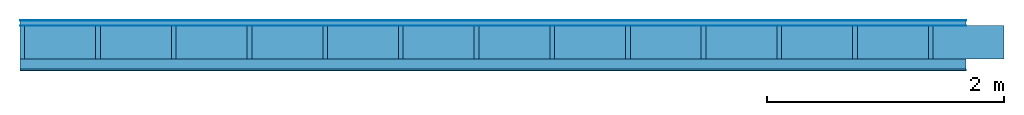
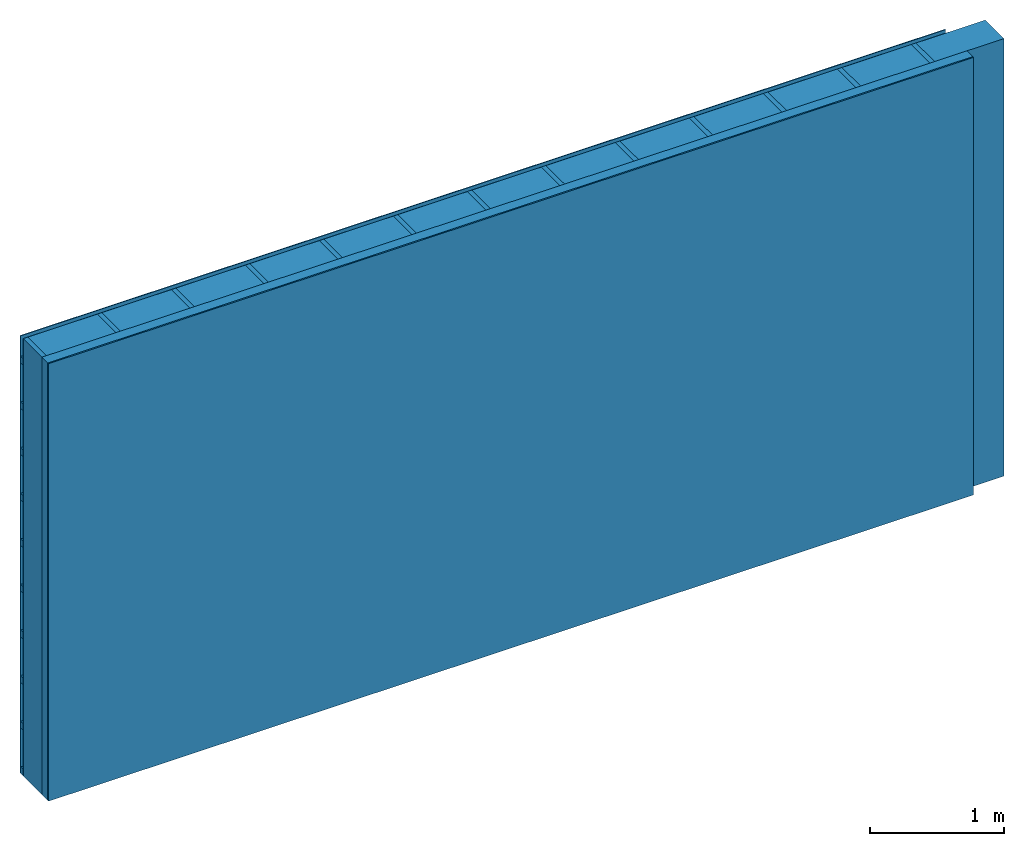
# One storey: 4 plates, 3 members, 1 element without a shape of its own.
"""IFC4 building model written with IfcOpenShell, lengths in metres."""

from ifc_helpers import new_model, si_unit, derived_unit, direction, frame, frame_2d, origin, origin_with_axes, place, context, project, spatial, rectangle, extrude, material, layer, layer_set, type_object, element, aggregate, save


model = new_model("IFC4")

# Units and contexts
plan_context = context("Plan", 3, precision=1e-05, world=origin(), true_north=direction((0.0, 1.0)))
model_context = context("Model", 3, precision=1e-05, world=origin(), true_north=direction((0.0, 1.0)))
ifc_project = project(units=[si_unit("LENGTHUNIT", "METRE"), derived_unit("SOUNDPRESSUREUNIT", [(si_unit("PRESSUREUNIT", "PASCAL", prefix="MICRO"), 0)]), si_unit("ENERGYUNIT", "JOULE", prefix="MEGA"), si_unit("MASSUNIT", "GRAM", prefix="KILO"), derived_unit("THERMALTRANSMITTANCEUNIT", [(si_unit("POWERUNIT", "WATT"), 1), (si_unit("AREAUNIT", "SQUARE_METRE"), -1), (si_unit("THERMODYNAMICTEMPERATUREUNIT", "KELVIN"), -1)]), derived_unit("AREADENSITYUNIT", [(si_unit("MASSUNIT", "GRAM", prefix="KILO"), 1), (si_unit("AREAUNIT", "SQUARE_METRE"), -1)]), derived_unit("USERDEFINED", [(si_unit("ENERGYUNIT", "JOULE", prefix="MEGA"), 1), (si_unit("AREAUNIT", "SQUARE_METRE"), -1)])], contexts=[plan_context, model_context])

# Site, building, storey
site = spatial("IfcSite", under=ifc_project)
building_placement = place(None, origin())
building = spatial("IfcBuilding", under=site, at=building_placement)
storey_placement = place(building_placement, origin())
storey = spatial("IfcBuildingStorey", under=building, at=storey_placement)

# Wall, members, plates
ifc_material_1 = material(Name="mineral, cement-based building board", Category="03.003")
ifc_layer_1 = layer(ifc_material_1, 0.008, Name="Cover 1st layer")
ifc_layer_2 = layer(None, 0.04, Name="Battens / profiles (ventilation)")
ifc_material_2 = material(Name="Vapor-permeable water barrier", Category="09.006")
ifc_layer_3 = layer(ifc_material_2, 0.0005, Name="outside 1st layer")
ifc_material_3 = material(Name="of the art")
ifc_layer_4 = layer(ifc_material_3, 0.0, Name="Bond")
ifc_layer_5 = layer(None, 0.28, Name="Support")
ifc_layer_6 = layer(ifc_material_3, 0.0, Name="Bond")
ifc_material_4 = material(Name="Solid timber panel")
ifc_layer_7 = layer(ifc_material_4, 0.087, Name="1st layer")
ifc_material_5 = material(Name="Plasterboard type A", Category="03.008")
ifc_layer_8 = layer(ifc_material_5, 0.0125, Name="Covering 1st layer")
ifc_material_6 = material(Name="joints", Category="04.017")
ifc_layer_9 = layer(ifc_material_6, 0.0, Name="Surface")
ifc_layer_set = layer_set([ifc_layer_1, ifc_layer_2, ifc_layer_3, ifc_layer_4, ifc_layer_5, ifc_layer_6, ifc_layer_7, ifc_layer_8, ifc_layer_9])
wall_type = type_object("IfcWallType", Name="D0997", PredefinedType="NOTDEFINED", material=ifc_layer_set)
wall_placement = place(None, frame((0.0, 0.0, 0.0), z_axis=(0.0, -1.0, 0.0), x_axis=(1.0, 0.0, 0.0)))
wall = element("IfcWall", 1, at=wall_placement, inside=storey, type_object=wall_type, material=ifc_layer_set, Name="Wall #1")
ifc_material_7 = material()
member_1_placement = place(wall_placement, origin())
member_1 = element("IfcMember", 2, at=member_1_placement, material=ifc_material_7, Name="Battens / profiles (ventilation)", context=plan_context, shape_type="SweptSolid", body=[
    extrude(rectangle(XDim=0.06, YDim=0.04, at=frame_2d((0.03, 0.02), x_axis=(1.0, 0.0))), frame((0.0, 0.0, 0.008), z_axis=(1.0, 0.0, 0.0), x_axis=(0.0, 1.0, 0.0)), (0.0, 0.0, 1.0), 8.0),
    extrude(rectangle(XDim=0.06, YDim=0.04, at=frame_2d((0.03, 0.02), x_axis=(1.0, 0.0))), frame((0.0, 0.417, 0.008), z_axis=(1.0, 0.0, 0.0), x_axis=(0.0, 1.0, 0.0)), (0.0, 0.0, 1.0), 8.0),
    extrude(rectangle(XDim=0.06, YDim=0.04, at=frame_2d((0.03, 0.02), x_axis=(1.0, 0.0))), frame((0.0, 0.834, 0.008), z_axis=(1.0, 0.0, 0.0), x_axis=(0.0, 1.0, 0.0)), (0.0, 0.0, 1.0), 8.0),
    extrude(rectangle(XDim=0.06, YDim=0.04, at=frame_2d((0.03, 0.02), x_axis=(1.0, 0.0))), frame((0.0, 1.251, 0.008), z_axis=(1.0, 0.0, 0.0), x_axis=(0.0, 1.0, 0.0)), (0.0, 0.0, 1.0), 8.0),
    extrude(rectangle(XDim=0.06, YDim=0.04, at=frame_2d((0.03, 0.02), x_axis=(1.0, 0.0))), frame((0.0, 1.668, 0.008), z_axis=(1.0, 0.0, 0.0), x_axis=(0.0, 1.0, 0.0)), (0.0, 0.0, 1.0), 8.0),
    extrude(rectangle(XDim=0.06, YDim=0.04, at=frame_2d((0.03, 0.02), x_axis=(1.0, 0.0))), frame((0.0, 2.085, 0.008), z_axis=(1.0, 0.0, 0.0), x_axis=(0.0, 1.0, 0.0)), (0.0, 0.0, 1.0), 8.0),
    extrude(rectangle(XDim=0.06, YDim=0.04, at=frame_2d((0.03, 0.02), x_axis=(1.0, 0.0))), frame((0.0, 2.502, 0.008), z_axis=(1.0, 0.0, 0.0), x_axis=(0.0, 1.0, 0.0)), (0.0, 0.0, 1.0), 8.0),
    extrude(rectangle(XDim=0.06, YDim=0.04, at=frame_2d((0.03, 0.02), x_axis=(1.0, 0.0))), frame((0.0, 2.919, 0.008), z_axis=(1.0, 0.0, 0.0), x_axis=(0.0, 1.0, 0.0)), (0.0, 0.0, 1.0), 8.0),
    extrude(rectangle(XDim=0.06, YDim=0.04, at=frame_2d((0.03, 0.02), x_axis=(1.0, 0.0))), frame((0.0, 3.336, 0.008), z_axis=(1.0, 0.0, 0.0), x_axis=(0.0, 1.0, 0.0)), (0.0, 0.0, 1.0), 8.0),
    extrude(rectangle(XDim=0.06, YDim=0.04, at=frame_2d((0.03, 0.02), x_axis=(1.0, 0.0))), frame((0.0, 3.753, 0.008), z_axis=(1.0, 0.0, 0.0), x_axis=(0.0, 1.0, 0.0)), (0.0, 0.0, 1.0), 8.0),
])
ifc_material_8 = material()
member_2_placement = place(wall_placement, origin())
member_2 = element("IfcMember", 3, at=member_2_placement, material=ifc_material_8, Name="Support", context=plan_context, shape_type="SweptSolid", body=[
    extrude(rectangle(XDim=0.04, YDim=0.28, at=frame_2d((0.02, 0.14), x_axis=(1.0, 0.0))), frame((0.0, 4.0, 0.0485), z_axis=(0.0, -1.0, 0.0), x_axis=(1.0, 0.0, 0.0)), (0.0, 0.0, 1.0), 4.0),
    extrude(rectangle(XDim=0.04, YDim=0.28, at=frame_2d((0.02, 0.14), x_axis=(1.0, 0.0))), frame((0.64, 4.0, 0.0485), z_axis=(0.0, -1.0, 0.0), x_axis=(1.0, 0.0, 0.0)), (0.0, 0.0, 1.0), 4.0),
    extrude(rectangle(XDim=0.04, YDim=0.28, at=frame_2d((0.02, 0.14), x_axis=(1.0, 0.0))), frame((1.28, 4.0, 0.0485), z_axis=(0.0, -1.0, 0.0), x_axis=(1.0, 0.0, 0.0)), (0.0, 0.0, 1.0), 4.0),
    extrude(rectangle(XDim=0.04, YDim=0.28, at=frame_2d((0.02, 0.14), x_axis=(1.0, 0.0))), frame((1.92, 4.0, 0.0485), z_axis=(0.0, -1.0, 0.0), x_axis=(1.0, 0.0, 0.0)), (0.0, 0.0, 1.0), 4.0),
    extrude(rectangle(XDim=0.04, YDim=0.28, at=frame_2d((0.02, 0.14), x_axis=(1.0, 0.0))), frame((2.56, 4.0, 0.0485), z_axis=(0.0, -1.0, 0.0), x_axis=(1.0, 0.0, 0.0)), (0.0, 0.0, 1.0), 4.0),
    extrude(rectangle(XDim=0.04, YDim=0.28, at=frame_2d((0.02, 0.14), x_axis=(1.0, 0.0))), frame((3.2, 4.0, 0.0485), z_axis=(0.0, -1.0, 0.0), x_axis=(1.0, 0.0, 0.0)), (0.0, 0.0, 1.0), 4.0),
    extrude(rectangle(XDim=0.04, YDim=0.28, at=frame_2d((0.02, 0.14), x_axis=(1.0, 0.0))), frame((3.84, 4.0, 0.0485), z_axis=(0.0, -1.0, 0.0), x_axis=(1.0, 0.0, 0.0)), (0.0, 0.0, 1.0), 4.0),
    extrude(rectangle(XDim=0.04, YDim=0.28, at=frame_2d((0.02, 0.14), x_axis=(1.0, 0.0))), frame((4.48, 4.0, 0.0485), z_axis=(0.0, -1.0, 0.0), x_axis=(1.0, 0.0, 0.0)), (0.0, 0.0, 1.0), 4.0),
    extrude(rectangle(XDim=0.04, YDim=0.28, at=frame_2d((0.02, 0.14), x_axis=(1.0, 0.0))), frame((5.12, 4.0, 0.0485), z_axis=(0.0, -1.0, 0.0), x_axis=(1.0, 0.0, 0.0)), (0.0, 0.0, 1.0), 4.0),
    extrude(rectangle(XDim=0.04, YDim=0.28, at=frame_2d((0.02, 0.14), x_axis=(1.0, 0.0))), frame((5.76, 4.0, 0.0485), z_axis=(0.0, -1.0, 0.0), x_axis=(1.0, 0.0, 0.0)), (0.0, 0.0, 1.0), 4.0),
    extrude(rectangle(XDim=0.04, YDim=0.28, at=frame_2d((0.02, 0.14), x_axis=(1.0, 0.0))), frame((6.4, 4.0, 0.0485), z_axis=(0.0, -1.0, 0.0), x_axis=(1.0, 0.0, 0.0)), (0.0, 0.0, 1.0), 4.0),
    extrude(rectangle(XDim=0.04, YDim=0.28, at=frame_2d((0.02, 0.14), x_axis=(1.0, 0.0))), frame((7.04, 4.0, 0.0485), z_axis=(0.0, -1.0, 0.0), x_axis=(1.0, 0.0, 0.0)), (0.0, 0.0, 1.0), 4.0),
    extrude(rectangle(XDim=0.04, YDim=0.28, at=frame_2d((0.02, 0.14), x_axis=(1.0, 0.0))), frame((7.68, 4.0, 0.0485), z_axis=(0.0, -1.0, 0.0), x_axis=(1.0, 0.0, 0.0)), (0.0, 0.0, 1.0), 4.0),
])
ifc_material_9 = material(Name="Mineral wool")
member_3_placement = place(wall_placement, origin())
member_3 = element("IfcMember", 4, at=member_3_placement, material=ifc_material_9, Name="Cavity", context=plan_context, shape_type="SweptSolid", body=[
    extrude(rectangle(XDim=0.6, YDim=0.28, at=frame_2d((0.3, 0.14), x_axis=(1.0, 0.0))), frame((0.04, 4.0, 0.0485), z_axis=(0.0, -1.0, 0.0), x_axis=(1.0, 0.0, 0.0)), (0.0, 0.0, 1.0), 4.0),
    extrude(rectangle(XDim=0.6, YDim=0.28, at=frame_2d((0.3, 0.14), x_axis=(1.0, 0.0))), frame((0.68, 4.0, 0.0485), z_axis=(0.0, -1.0, 0.0), x_axis=(1.0, 0.0, 0.0)), (0.0, 0.0, 1.0), 4.0),
    extrude(rectangle(XDim=0.6, YDim=0.28, at=frame_2d((0.3, 0.14), x_axis=(1.0, 0.0))), frame((1.32, 4.0, 0.0485), z_axis=(0.0, -1.0, 0.0), x_axis=(1.0, 0.0, 0.0)), (0.0, 0.0, 1.0), 4.0),
    extrude(rectangle(XDim=0.6, YDim=0.28, at=frame_2d((0.3, 0.14), x_axis=(1.0, 0.0))), frame((1.96, 4.0, 0.0485), z_axis=(0.0, -1.0, 0.0), x_axis=(1.0, 0.0, 0.0)), (0.0, 0.0, 1.0), 4.0),
    extrude(rectangle(XDim=0.6, YDim=0.28, at=frame_2d((0.3, 0.14), x_axis=(1.0, 0.0))), frame((2.6, 4.0, 0.0485), z_axis=(0.0, -1.0, 0.0), x_axis=(1.0, 0.0, 0.0)), (0.0, 0.0, 1.0), 4.0),
    extrude(rectangle(XDim=0.6, YDim=0.28, at=frame_2d((0.3, 0.14), x_axis=(1.0, 0.0))), frame((3.24, 4.0, 0.0485), z_axis=(0.0, -1.0, 0.0), x_axis=(1.0, 0.0, 0.0)), (0.0, 0.0, 1.0), 4.0),
    extrude(rectangle(XDim=0.6, YDim=0.28, at=frame_2d((0.3, 0.14), x_axis=(1.0, 0.0))), frame((3.88, 4.0, 0.0485), z_axis=(0.0, -1.0, 0.0), x_axis=(1.0, 0.0, 0.0)), (0.0, 0.0, 1.0), 4.0),
    extrude(rectangle(XDim=0.6, YDim=0.28, at=frame_2d((0.3, 0.14), x_axis=(1.0, 0.0))), frame((4.52, 4.0, 0.0485), z_axis=(0.0, -1.0, 0.0), x_axis=(1.0, 0.0, 0.0)), (0.0, 0.0, 1.0), 4.0),
    extrude(rectangle(XDim=0.6, YDim=0.28, at=frame_2d((0.3, 0.14), x_axis=(1.0, 0.0))), frame((5.16, 4.0, 0.0485), z_axis=(0.0, -1.0, 0.0), x_axis=(1.0, 0.0, 0.0)), (0.0, 0.0, 1.0), 4.0),
    extrude(rectangle(XDim=0.6, YDim=0.28, at=frame_2d((0.3, 0.14), x_axis=(1.0, 0.0))), frame((5.8, 4.0, 0.0485), z_axis=(0.0, -1.0, 0.0), x_axis=(1.0, 0.0, 0.0)), (0.0, 0.0, 1.0), 4.0),
    extrude(rectangle(XDim=0.6, YDim=0.28, at=frame_2d((0.3, 0.14), x_axis=(1.0, 0.0))), frame((6.44, 4.0, 0.0485), z_axis=(0.0, -1.0, 0.0), x_axis=(1.0, 0.0, 0.0)), (0.0, 0.0, 1.0), 4.0),
    extrude(rectangle(XDim=0.6, YDim=0.28, at=frame_2d((0.3, 0.14), x_axis=(1.0, 0.0))), frame((7.08, 4.0, 0.0485), z_axis=(0.0, -1.0, 0.0), x_axis=(1.0, 0.0, 0.0)), (0.0, 0.0, 1.0), 4.0),
    extrude(rectangle(XDim=0.6, YDim=0.28, at=frame_2d((0.3, 0.14), x_axis=(1.0, 0.0))), frame((7.72, 4.0, 0.0485), z_axis=(0.0, -1.0, 0.0), x_axis=(1.0, 0.0, 0.0)), (0.0, 0.0, 1.0), 4.0),
])
plate_1_placement = place(wall_placement, origin())
plate_1 = element("IfcPlate", 5, at=plate_1_placement, material=ifc_material_1, Name="Cover 1st layer", context=plan_context, shape_type="SweptSolid", body=[
    extrude(rectangle(XDim=8.0, YDim=4.0, at=frame_2d((4.0, 2.0), x_axis=(1.0, 0.0))), origin_with_axes(), (0.0, 0.0, 1.0), 0.008),
])
plate_2_placement = place(wall_placement, origin())
plate_2 = element("IfcPlate", 6, at=plate_2_placement, material=ifc_material_2, Name="outside 1st layer", context=plan_context, shape_type="SweptSolid", body=[
    extrude(rectangle(XDim=8.0, YDim=4.0, at=frame_2d((4.0, 2.0), x_axis=(1.0, 0.0))), frame((0.0, 0.0, 0.048), z_axis=(0.0, 0.0, 1.0), x_axis=(1.0, 0.0, 0.0)), (0.0, 0.0, 1.0), 0.0005),
])
plate_3_placement = place(wall_placement, origin())
plate_3 = element("IfcPlate", 7, at=plate_3_placement, material=ifc_material_4, Name="1st layer", context=plan_context, shape_type="SweptSolid", body=[
    extrude(rectangle(XDim=8.0, YDim=4.0, at=frame_2d((4.0, 2.0), x_axis=(1.0, 0.0))), frame((0.0, 0.0, 0.3285), z_axis=(0.0, 0.0, 1.0), x_axis=(1.0, 0.0, 0.0)), (0.0, 0.0, 1.0), 0.087),
])
plate_4_placement = place(wall_placement, origin())
plate_4 = element("IfcPlate", 8, at=plate_4_placement, material=ifc_material_5, Name="Covering 1st layer", context=plan_context, shape_type="SweptSolid", body=[
    extrude(rectangle(XDim=8.0, YDim=4.0, at=frame_2d((4.0, 2.0), x_axis=(1.0, 0.0))), frame((0.0, 0.0, 0.4155), z_axis=(0.0, 0.0, 1.0), x_axis=(1.0, 0.0, 0.0)), (0.0, 0.0, 1.0), 0.0125),
])
aggregate(wall, [plate_1, member_1, plate_2, member_2, member_3, plate_3, plate_4])

save(model, "model.ifc")
